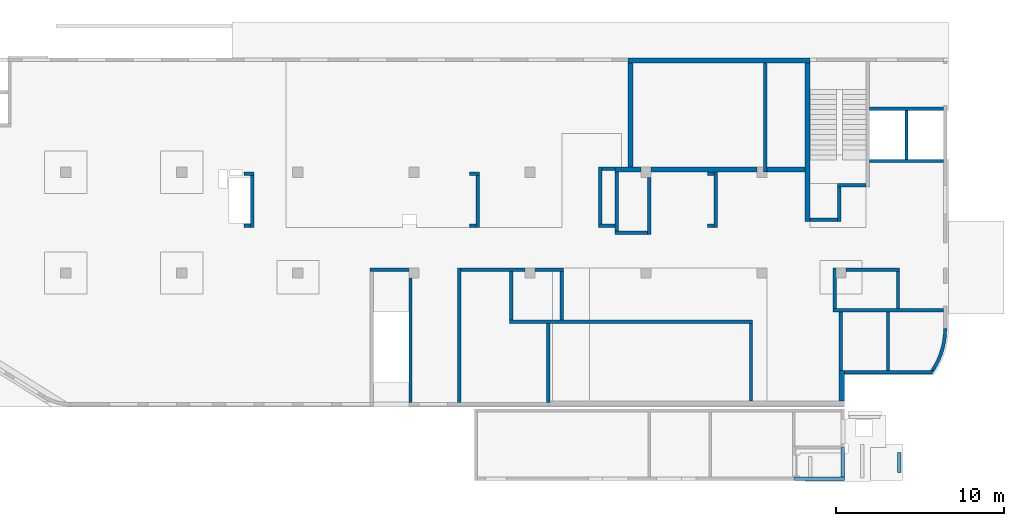
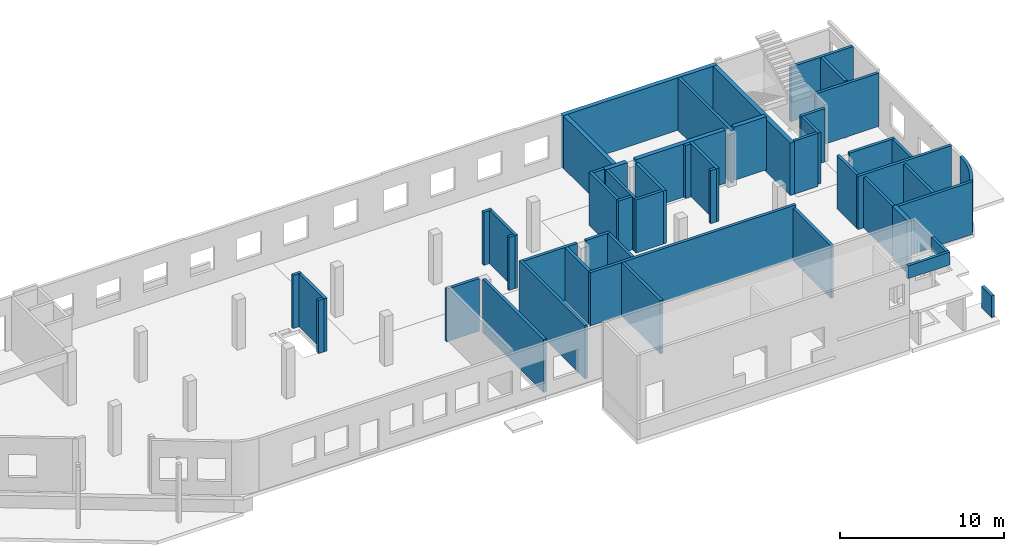
# One storey, part 3 of 8: 50 walls.
"""IFC4 building model written with IfcOpenShell, lengths in millimetres."""

import ifcopenshell
import ifcopenshell.guid

model = None  # the IFC model being written
_history = None  # IfcOwnerHistory: only IFC2X3 demands one
_inside = {}  # id of a spatial element -> (the spatial element, [elements in it])
_under = {}  # id of a project, library or spatial element -> (it, [spatial elements below it])
_declared = {}  # id of a project -> (the project, [libraries it declares])
_typed = {}  # id of a type object -> (the type object, [elements of that type])
_made_of = {}  # id of a material, layer set ... -> (it, [elements and type objects made of it])


def new_model(schema):
    """Start an empty IFC model of exactly this schema.

    Asked for "IFC4X3", IfcOpenShell would pick the latest addendum, in which some entities
    have other attributes; the version numbers below select the first issue.
    IFC2X3 requires an IfcOwnerHistory on every rooted entity: one is made here for all.
    """
    global model, _history
    if schema == "IFC4X3":
        model = ifcopenshell.file(schema_version=(4, 3, 0, 0))
    else:
        model = ifcopenshell.file(schema=schema)
    _inside.clear()
    _under.clear()
    _declared.clear()
    _typed.clear()
    _made_of.clear()
    _history = None
    if model.schema == "IFC2X3":
        org = make("IfcOrganization", Name="unknown")
        user = make(
            "IfcPersonAndOrganization",
            ThePerson=make("IfcPerson", FamilyName="unknown"),
            TheOrganization=org,
        )
        app = make(
            "IfcApplication",
            ApplicationDeveloper=org,
            Version="unknown",
            ApplicationFullName="unknown",
            ApplicationIdentifier="unknown",
        )
        _history = make(
            "IfcOwnerHistory",
            OwningUser=user,
            OwningApplication=app,
            ChangeAction="ADDED",
            CreationDate=0,
        )
    return model


def make(cls, **values):
    """One entity of the class cls with the attributes given. An attribute that is None is left unset."""
    return model.create_entity(
        cls, **{name: value for name, value in values.items() if value is not None}
    )


def entity(cls, *values):
    """Any entity or typed value of the class cls, its attributes in the order of the schema. None: left unset."""
    e = model.create_entity(cls)
    for i, value in enumerate(values):
        if value is not None:
            e[i] = value
    return e


def rooted(cls, **values):
    """An entity with a GlobalId (a new one), such as an element, a storey or a relation."""
    return make(cls, GlobalId=ifcopenshell.guid.new(), OwnerHistory=_history, **values)


def si_unit(unit_type, name, prefix=None):
    """IfcSIUnit, for example si_unit("LENGTHUNIT", "METRE", prefix="MILLI")."""
    return make("IfcSIUnit", UnitType=unit_type, Prefix=prefix, Name=name)


def converted_unit(unit_type, name, factor, base, dimensions=None, offset=None):
    """IfcConversionBasedUnit, such as the inch: factor (a typed value) times the base unit."""
    return make(
        "IfcConversionBasedUnit"
        if offset is None
        else "IfcConversionBasedUnitWithOffset",
        ConversionOffset=offset,
        Dimensions=None
        if dimensions is None
        else entity("IfcDimensionalExponents", *dimensions),
        UnitType=unit_type,
        Name=name,
        ConversionFactor=make(
            "IfcMeasureWithUnit", ValueComponent=factor, UnitComponent=base
        ),
    )


def derived_unit(unit_type, elements):
    """IfcDerivedUnit: a product of units, each with its exponent."""
    return make(
        "IfcDerivedUnit",
        Elements=[
            make("IfcDerivedUnitElement", Unit=unit, Exponent=power)
            for unit, power in elements
        ],
        UnitType=unit_type,
    )


def assignment(units):
    """IfcUnitAssignment: the units of a project."""
    return None if units is None else make("IfcUnitAssignment", Units=units)


def point(xyz):
    """IfcCartesianPoint."""
    return None if xyz is None else make("IfcCartesianPoint", Coordinates=xyz)


def direction(xyz):
    """IfcDirection."""
    return None if xyz is None else make("IfcDirection", DirectionRatios=xyz)


def frame(location, z_axis=None, x_axis=None):
    """IfcAxis2Placement3D, a coordinate frame: its origin and axes. An axis left out is left unset."""
    return make(
        "IfcAxis2Placement3D",
        Location=point(location),
        Axis=direction(z_axis),
        RefDirection=direction(x_axis),
    )


def origin():
    """The frame at (0, 0, 0) with its axes left unset."""
    return frame((0.0, 0.0, 0.0))


def place(relative_to, where):
    """IfcLocalPlacement: puts the frame where relative to a parent placement (None: the world)."""
    return make(
        "IfcLocalPlacement", PlacementRelTo=relative_to, RelativePlacement=where
    )


def context(
    kind, dimensions, precision=None, world=None, true_north=None, identifier=None
):
    """IfcGeometricRepresentationContext, for example the 3D "Model" context."""
    return make(
        "IfcGeometricRepresentationContext",
        ContextIdentifier=identifier,
        ContextType=kind,
        CoordinateSpaceDimension=dimensions,
        Precision=precision,
        WorldCoordinateSystem=world,
        TrueNorth=true_north,
    )


def subcontext(parent, identifier, kind, view, scale=None):
    """IfcGeometricRepresentationSubContext, for example "Body" below "Model"."""
    return make(
        "IfcGeometricRepresentationSubContext",
        ContextIdentifier=identifier,
        ContextType=kind,
        ParentContext=parent,
        TargetScale=scale,
        TargetView=view,
    )


def project(units=None, contexts=None):
    """IfcProject with its units and contexts."""
    return rooted(
        "IfcProject",
        Name="project",
        RepresentationContexts=contexts,
        UnitsInContext=assignment(units),
    )


def spatial(cls, under=None, at=None, **own):
    """A site, building, storey or space (cls), placed at a placement, below another one or the project."""
    s = rooted(cls, ObjectPlacement=at, **own)
    if under is not None:
        _under.setdefault(under.id(), (under, []))[1].append(s)
    return s


def point_list(points):
    """IfcCartesianPointList2D or 3D."""
    cls = (
        "IfcCartesianPointList2D" if len(points[0]) == 2 else "IfcCartesianPointList3D"
    )
    return make(cls, CoordList=points)


def indexed_curve(points, segments=None, self_intersect=None):
    """IfcIndexedPolyCurve: lines and arcs through numbered points (the first is 1)."""
    return make(
        "IfcIndexedPolyCurve",
        Points=point_list(points),
        Segments=segments,
        SelfIntersect=self_intersect,
    )


def outline(outer, holes=None, kind="AREA"):
    """IfcArbitraryClosedProfileDef: a profile drawn as a closed curve; with holes, ...WithVoids."""
    if holes is None:
        return make("IfcArbitraryClosedProfileDef", ProfileType=kind, OuterCurve=outer)
    return make(
        "IfcArbitraryProfileDefWithVoids",
        ProfileType=kind,
        OuterCurve=outer,
        InnerCurves=holes,
    )


def extrude(swept, where, along, depth):
    """IfcExtrudedAreaSolid: the profile swept, set in the frame where, extruded along a direction by depth."""
    return make(
        "IfcExtrudedAreaSolid",
        SweptArea=swept,
        Position=where,
        ExtrudedDirection=direction(along),
        Depth=depth,
    )


def shape(context_of_items, identifier, shape_type, items):
    """IfcShapeRepresentation: the items that make up one representation, for example the "Body"."""
    return make(
        "IfcShapeRepresentation",
        ContextOfItems=context_of_items,
        RepresentationIdentifier=identifier,
        RepresentationType=shape_type,
        Items=items,
    )


def material(Name=None, Category=None):
    """IfcMaterial."""
    return make("IfcMaterial", Name=Name, Category=Category)


def made_of(thing, what):
    """Note that an element or type object is made of a material, layer set ...; save() writes the relation."""
    if what is not None:
        _made_of.setdefault(what.id(), (what, []))[1].append(thing)
    return thing


def type_object(cls, material=None, **own):
    """A type object (cls), such as IfcWallType, which elements share."""
    return made_of(rooted(cls, **own), material)


def element(
    cls,
    number,
    at=None,
    inside=None,
    cuts=None,
    type_object=None,
    material=None,
    context=None,
    identifier="Body",
    shape_type=None,
    held_by="IfcProductDefinitionShape",
    body=None,
    shapes=None,
    **own,
):
    """One element of the class cls, such as IfcWall. Its Tag is "e" and its number.

    at: its placement. inside: the storey or other place that contains it. cuts: it is an
    opening in that element (IfcRelVoidsElement). A single representation is given by context,
    identifier, shape_type and body (its items); several are given by shapes. held_by: the class
    of the entity that holds the representations. save() writes the other relations.
    """
    e = rooted(cls, Tag="e%d" % number, ObjectPlacement=at, **own)
    if body is not None:
        shapes = [shape(context, identifier, shape_type, body)]
    if shapes is not None:
        e.Representation = make(held_by, Representations=shapes)
    if inside is not None:
        _inside.setdefault(inside.id(), (inside, []))[1].append(e)
    if cuts is not None:
        rooted(
            "IfcRelVoidsElement", RelatingBuildingElement=cuts, RelatedOpeningElement=e
        )
    if type_object is not None:
        _typed.setdefault(type_object.id(), (type_object, []))[1].append(e)
    return made_of(e, material)


def aggregate(whole, parts):
    """IfcRelAggregates: a whole, such as a stair, and the parts it consists of."""
    return rooted("IfcRelAggregates", RelatingObject=whole, RelatedObjects=parts)


def save(model, path):
    """Write the relations noted so far, then the file.

    IfcRelAggregates (storeys below a building ...), IfcRelContainedInSpatialStructure (elements
    in a storey), IfcRelDefinesByType, IfcRelAssociatesMaterial and IfcRelDeclares: one each for
    every whole, place, type object, material and project.
    """
    for whole, parts in _under.values():
        aggregate(whole, parts)
    for where, things in _inside.values():
        rooted(
            "IfcRelContainedInSpatialStructure",
            RelatedElements=things,
            RelatingStructure=where,
        )
    for kind, things in _typed.values():
        rooted("IfcRelDefinesByType", RelatedObjects=things, RelatingType=kind)
    for what, things in _made_of.values():
        rooted("IfcRelAssociatesMaterial", RelatedObjects=things, RelatingMaterial=what)
    for by, libraries in _declared.values():
        rooted("IfcRelDeclares", RelatingContext=by, RelatedDefinitions=libraries)
    model.write(path)


model = new_model("IFC4")

# Units and contexts
model_context = context("Model", 3, precision=0.01, world=origin(), true_north=direction((6.12303176911189e-17, 1.0)))
plan_context = context("Plan", 3, precision=0.01, world=origin(), true_north=direction((6.12303176911189e-17, 1.0)))
body_context = subcontext(model_context, "Body", "Model", "MODEL_VIEW")
ifc_project = project(units=[si_unit("LENGTHUNIT", "METRE", prefix="MILLI"), si_unit("AREAUNIT", "SQUARE_METRE"), si_unit("VOLUMEUNIT", "CUBIC_METRE"), converted_unit("PLANEANGLEUNIT", "DEGREE", entity("IfcRatioMeasure", 0.0174532925199433), si_unit("PLANEANGLEUNIT", "RADIAN"), dimensions=[0, 0, 0, 0, 0, 0, 0]), si_unit("MASSUNIT", "GRAM", prefix="KILO"), derived_unit("MASSDENSITYUNIT", [(si_unit("MASSUNIT", "GRAM", prefix="KILO"), 1), (si_unit("LENGTHUNIT", "METRE"), -3)]), derived_unit("MOMENTOFINERTIAUNIT", [(si_unit("LENGTHUNIT", "METRE"), 4)]), si_unit("TIMEUNIT", "SECOND"), si_unit("FREQUENCYUNIT", "HERTZ"), si_unit("THERMODYNAMICTEMPERATUREUNIT", "DEGREE_CELSIUS"), derived_unit("THERMALTRANSMITTANCEUNIT", [(si_unit("MASSUNIT", "GRAM", prefix="KILO"), 1), (si_unit("THERMODYNAMICTEMPERATUREUNIT", "KELVIN"), -1), (si_unit("TIMEUNIT", "SECOND"), -3)]), derived_unit("VOLUMETRICFLOWRATEUNIT", [(si_unit("LENGTHUNIT", "METRE"), 3), (si_unit("TIMEUNIT", "SECOND"), -1)]), derived_unit("MASSFLOWRATEUNIT", [(si_unit("MASSUNIT", "GRAM", prefix="KILO"), 1), (si_unit("TIMEUNIT", "SECOND"), -1)]), derived_unit("ROTATIONALFREQUENCYUNIT", [(si_unit("TIMEUNIT", "SECOND"), -1)]), si_unit("ELECTRICCURRENTUNIT", "AMPERE"), si_unit("ELECTRICVOLTAGEUNIT", "VOLT"), si_unit("POWERUNIT", "WATT"), si_unit("FORCEUNIT", "NEWTON", prefix="KILO"), si_unit("ILLUMINANCEUNIT", "LUX"), si_unit("LUMINOUSFLUXUNIT", "LUMEN"), si_unit("LUMINOUSINTENSITYUNIT", "CANDELA"), derived_unit("USERDEFINED", [(si_unit("MASSUNIT", "GRAM", prefix="KILO"), -1), (si_unit("LENGTHUNIT", "METRE"), -2), (si_unit("TIMEUNIT", "SECOND"), 3), (si_unit("LUMINOUSFLUXUNIT", "LUMEN"), 1)]), derived_unit("LINEARVELOCITYUNIT", [(si_unit("LENGTHUNIT", "METRE"), 1), (si_unit("TIMEUNIT", "SECOND"), -1)]), si_unit("PRESSUREUNIT", "PASCAL"), derived_unit("USERDEFINED", [(si_unit("LENGTHUNIT", "METRE"), -2), (si_unit("MASSUNIT", "GRAM", prefix="KILO"), 1), (si_unit("TIMEUNIT", "SECOND"), -2)]), derived_unit("LINEARFORCEUNIT", [(si_unit("MASSUNIT", "GRAM", prefix="KILO"), 1), (si_unit("LENGTHUNIT", "METRE"), 1), (si_unit("TIMEUNIT", "SECOND"), -2), (si_unit("LENGTHUNIT", "METRE"), -1)]), derived_unit("PLANARFORCEUNIT", [(si_unit("MASSUNIT", "GRAM", prefix="KILO"), 1), (si_unit("LENGTHUNIT", "METRE"), 1), (si_unit("TIMEUNIT", "SECOND"), -2), (si_unit("LENGTHUNIT", "METRE"), -2)])], contexts=[model_context, plan_context])

# Site, building, storey
site_placement = place(None, origin())
site = spatial("IfcSite", under=ifc_project, at=site_placement, CompositionType="ELEMENT")
building_placement = place(site_placement, origin())
building = spatial("IfcBuilding", under=site, at=building_placement, CompositionType="ELEMENT")
storey_placement = place(building_placement, origin())
storey = spatial("IfcBuildingStorey", under=building, at=storey_placement, CompositionType="ELEMENT", Elevation=0.0)

# Walls
ifc_material = material()
wall_type_1 = type_object("IfcWallType", PredefinedType="STANDARD")
wall_1_placement = place(storey_placement, frame((41670.0002685547, 7399.99922635609, 0.0), z_axis=(0.0, 0.0, 1.0), x_axis=(0.0, -1.0, 0.0)))
element("IfcWall", 1, at=wall_1_placement, inside=storey, type_object=wall_type_1, material=ifc_material, PredefinedType="NOTDEFINED", context=body_context, shape_type="SweptSolid", body=[
    extrude(outline(indexed_curve([(7399.9999999999, 100.000000000003), (-1.17863088903232e-13, 100.000000000003), (1.17863088903232e-13, -100.000000000003), (7399.9999999999, -100.000000000003), (7399.9999999999, 100.000000000003)], self_intersect=False)), origin(), (0.0, 0.0, 1.0), 3950.0),
])
wall_2_placement = place(storey_placement, frame((41570.0002685547, 7899.99922635609, -150.0), z_axis=(0.0, 0.0, 1.0), x_axis=(-1.0, 0.0, 0.0)))
element("IfcWall", 2, at=wall_2_placement, inside=storey, type_object=wall_type_1, material=ifc_material, PredefinedType="NOTDEFINED", context=body_context, shape_type="SweptSolid", body=[
    extrude(outline(indexed_curve([(2300.00000000001, 100.0), (-3.29568256742987e-13, 100.0), (3.29568256742987e-13, -100.0), (2300.00000000001, -100.0), (2300.00000000001, 100.0)], self_intersect=False)), origin(), (0.0, 0.0, 1.0), 3900.0),
])
wall_3_placement = place(storey_placement, frame((44570.0002685546, -0.000773643820389016, 0.0), z_axis=(0.0, 0.0, 1.0), x_axis=(0.0, 1.0, 0.0)))
element("IfcWall", 3, at=wall_3_placement, inside=storey, type_object=wall_type_1, material=ifc_material, PredefinedType="NOTDEFINED", context=body_context, shape_type="SweptSolid", body=[
    extrude(outline(indexed_curve([(7999.9999999999, 100.000000000007), (-3.96878629442861e-20, 100.000000000003), (3.96878629442861e-20, -100.000000000003), (7999.9999999999, -99.9999999999995), (7999.9999999999, 100.000000000007)], self_intersect=False)), origin(), (0.0, 0.0, 1.0), 3950.0),
])
wall_4_placement = place(storey_placement, frame((48470.0002685546, 7899.99922635607, 0.0), z_axis=(0.0, 0.0, 1.0), x_axis=(-1.0, 0.0, 0.0)))
element("IfcWall", 4, at=wall_4_placement, inside=storey, type_object=wall_type_1, material=ifc_material, PredefinedType="NOTDEFINED", context=body_context, shape_type="SweptSolid", body=[
    extrude(outline(indexed_curve([(3800.0, 100.0), (-3.42426881021964e-13, 100.0), (3.42426881021964e-13, -100.0), (3800.0, -100.0), (3800.0, 100.0)], self_intersect=False)), origin(), (0.0, 0.0, 1.0), 3950.0),
])
wall_5_placement = place(storey_placement, frame((49070.0002685546, 7899.99922635606, 0.0)))
element("IfcWall", 5, at=wall_5_placement, inside=storey, type_object=wall_type_1, material=ifc_material, PredefinedType="NOTDEFINED", context=body_context, shape_type="SweptSolid", body=[
    extrude(outline(indexed_curve([(1700.0, 100.0), (-3.18490332146586e-13, 100.0), (3.18490332146586e-13, -100.0), (1700.0, -100.0), (1700.0, 100.0)], self_intersect=False)), origin(), (0.0, 0.0, 1.0), 3950.0),
])
wall_6_placement = place(storey_placement, frame((50670.0002685546, 7799.99922635606, 0.0), z_axis=(0.0, 0.0, 1.0), x_axis=(0.0, -1.0, 0.0)))
element("IfcWall", 6, at=wall_6_placement, inside=storey, type_object=wall_type_1, material=ifc_material, PredefinedType="NOTDEFINED", context=body_context, shape_type="SweptSolid", body=[
    extrude(outline(indexed_curve([(2899.99999999996, 100.000000000003), (0.0, 100.000000000003), (0.0, -100.000000000003), (2899.99999999996, -100.000000000003), (2899.99999999996, 100.000000000003)], self_intersect=False)), origin(), (0.0, 0.0, 1.0), 3950.0),
])
wall_7_placement = place(storey_placement, frame((62020.0002685547, 4799.99922635607, 0.0), z_axis=(0.0, 0.0, 1.0), x_axis=(-1.0, 0.0, 0.0)))
element("IfcWall", 7, at=wall_7_placement, inside=storey, type_object=wall_type_1, material=ifc_material, PredefinedType="NOTDEFINED", context=body_context, shape_type="SweptSolid", body=[
    extrude(outline(indexed_curve([(14450.0, 99.9999999999999), (-3.06338005499363e-13, 100.0), (3.06338005499363e-13, -100.0), (14450.0, -100.0), (14450.0, 99.9999999999999)], self_intersect=False)), origin(), (0.0, 0.0, 1.0), 3950.0),
])
wall_8_placement = place(storey_placement, frame((47670.0002685546, 7799.99922635607, 0.0), z_axis=(0.0, 0.0, 1.0), x_axis=(0.0, -1.0, 0.0)))
element("IfcWall", 8, at=wall_8_placement, inside=storey, type_object=wall_type_1, material=ifc_material, PredefinedType="NOTDEFINED", context=body_context, shape_type="SweptSolid", body=[
    extrude(outline(indexed_curve([(2899.99999999996, 100.000000000003), (0.0, 100.000000000003), (0.0, -100.000000000003), (2899.99999999996, -100.000000000003), (2899.99999999996, 100.000000000003)], self_intersect=False)), origin(), (0.0, 0.0, 1.0), 3950.0),
])
wall_9_placement = place(storey_placement, frame((49870.0002685546, -0.000773643837420837, 0.0), z_axis=(0.0, 0.0, 1.0), x_axis=(0.0, 1.0, 0.0)))
element("IfcWall", 9, at=wall_9_placement, inside=storey, type_object=wall_type_1, material=ifc_material, PredefinedType="NOTDEFINED", context=body_context, shape_type="SweptSolid", body=[
    extrude(outline(indexed_curve([(4699.99999999994, 99.9999999999998), (3.10976382565532e-20, 100.000000000003), (-3.10976382565532e-20, -100.000000000003), (4699.99999999994, -100.000000000007), (4699.99999999994, 99.9999999999998)], self_intersect=False)), origin(), (0.0, 0.0, 1.0), 3950.0),
])
wall_10_placement = place(storey_placement, frame((61920.0002685546, 4699.99922635607, -150.0), z_axis=(0.0, 0.0, 1.0), x_axis=(0.0, -1.0, 0.0)))
element("IfcWall", 10, at=wall_10_placement, inside=storey, type_object=wall_type_1, material=ifc_material, PredefinedType="NOTDEFINED", context=body_context, shape_type="SweptSolid", body=[
    extrude(outline(indexed_curve([(4599.99999999994, 100.000000000006), (-2.40637139844096e-13, 100.000000000003), (2.40637139844096e-13, -100.000000000003), (4599.99999999994, -100.000000000001), (4599.99999999994, 100.000000000006)], self_intersect=False)), origin(), (0.0, 0.0, 1.0), 3900.0),
])
wall_11_placement = place(storey_placement, frame((67270.0002685546, 1794.99922635611, 0.0), z_axis=(0.0, 0.0, 1.0), x_axis=(0.0, 1.0, 0.0)))
element("IfcWall", 11, at=wall_11_placement, inside=storey, type_object=wall_type_1, material=ifc_material, PredefinedType="NOTDEFINED", context=body_context, shape_type="SweptSolid", body=[
    extrude(outline(indexed_curve([(3604.99999999987, 100.000000000006), (-4.66276854653109e-14, 100.000000000003), (4.66276854653109e-14, -100.000000000003), (3604.99999999987, -100.0), (3604.99999999987, 100.000000000006)], self_intersect=False)), origin(), (0.0, 0.0, 1.0), 3750.0),
])
wall_12_placement = place(storey_placement, frame((67370.0002685546, 1794.99922635611, -150.0)))
element("IfcWall", 12, at=wall_12_placement, inside=storey, type_object=wall_type_1, material=ifc_material, PredefinedType="NOTDEFINED", context=body_context, shape_type="SweptSolid", body=[
    extrude(outline(indexed_curve([(5320.61392813742, -100.000000000023), (5334.83556171488, -80.3298207855378), (5348.9532041316, -60.584872456016), (5362.96646230287, -40.7657047800855), (5376.87494605046, -20.8728695928891), (5390.67826811337, -0.906920780744112), (5404.3760441587, 19.1315857343014), (5417.96789279233, 39.2420920099402), (5431.45343556949, 59.4240380991268), (5444.83229700539, 79.6768620656952), (5458.10410458558, 99.999999999978), (5217.31502339911, 100.0), (99.9999999999943, 100.0), (99.9999999999949, -100.0), (5320.61392813742, -100.000000000023)], self_intersect=False)), origin(), (0.0, 0.0, 1.0), 3900.0),
])
wall_13_placement = place(storey_placement, frame((66795.0, 5499.99922635598, 0.0)))
element("IfcWall", 13, at=wall_13_placement, inside=storey, type_object=wall_type_1, material=ifc_material, PredefinedType="NOTDEFINED", context=body_context, shape_type="SweptSolid", body=[
    extrude(outline(indexed_curve([(6575.0002685548, 100.000000000001), (-3.21116670446023e-13, 100.0), (3.21116670446023e-13, -100.0), (6575.0002685548, -99.9999999999995), (6575.0002685548, 100.000000000001)], self_intersect=False)), origin(), (0.0, 0.0, 1.0), 3950.0),
])
wall_14_placement = place(storey_placement, frame((73470.0002685546, 4399.99913385884, -150.0)))
element("IfcWall", 14, at=wall_14_placement, inside=storey, type_object=wall_type_1, material=ifc_material, PredefinedType="NOTDEFINED", context=body_context, shape_type="SweptSolid", body=[
    extrude(outline(indexed_curve([(-641.895895414368, -2504.99990750277), (-504.115533634932, -2278.7932507463), (-379.582920453029, -2045.03160310687), (-268.710923968226, -1804.489964199), (-171.867122675117, -1557.96581162138), (-89.3725868152551, -1306.27645704658), (-21.500813919721, -1050.25633655401), (31.5231779285028, -790.754244189626), (69.5235961062065, -528.630517924081), (92.3744562625127, -264.754187338847), (99.9999999999513, -9.2496628161598e-05), (-99.9999999999599, 9.24965686039059e-05), (-108.068327086898, -266.334566127823), (-132.243226652315, -531.692480118633), (-172.436042031252, -795.100501785527), (-228.499374019115, -1055.59263428279), (-300.227621429127, -1312.21357421178), (-387.357735094033, -1564.02221500731), (-489.570182546934, -1810.0950982599), (-606.490119843403, -2049.52980031693), (-737.688766227591, -2281.44824174303), (-882.684976600846, -2504.99990750275), (-641.895895414368, -2504.99990750277)], self_intersect=False)), origin(), (0.0, 0.0, 1.0), 3900.0),
])
wall_15_placement = place(storey_placement, frame((66895.0, 7999.99922635617, 0.0), z_axis=(0.0, 0.0, 1.0), x_axis=(0.0, -1.0, 0.0)))
element("IfcWall", 15, at=wall_15_placement, inside=storey, type_object=wall_type_1, material=ifc_material, PredefinedType="NOTDEFINED", context=body_context, shape_type="SweptSolid", body=[
    extrude(outline(indexed_curve([(2400.0000000002, 100.000000000003), (0.0, 100.000000000003), (0.0, -100.000000000003), (2400.0000000002, -100.000000000003), (2400.0000000002, 100.000000000003)], self_intersect=False)), origin(), (0.0, 0.0, 1.0), 3950.0),
])
wall_16_placement = place(storey_placement, frame((67570.0002685546, 7899.99922635617, 0.0)))
element("IfcWall", 16, at=wall_16_placement, inside=storey, type_object=wall_type_1, material=ifc_material, PredefinedType="NOTDEFINED", context=body_context, shape_type="SweptSolid", body=[
    extrude(outline(indexed_curve([(3200.0, 99.9999999999998), (-3.30452149995528e-13, 100.0), (3.30452149995528e-13, -100.0), (3200.0, -100.0), (3200.0, 99.9999999999998)], self_intersect=False)), origin(), (0.0, 0.0, 1.0), 3950.0),
])
wall_17_placement = place(storey_placement, frame((70670.0002685546, 7799.99922635617, 0.0), z_axis=(0.0, 0.0, 1.0), x_axis=(0.0, -1.0, 0.0)))
element("IfcWall", 17, at=wall_17_placement, inside=storey, type_object=wall_type_1, material=ifc_material, PredefinedType="NOTDEFINED", context=body_context, shape_type="SweptSolid", body=[
    extrude(outline(indexed_curve([(2200.0000000002, 100.000000000003), (0.0, 100.000000000003), (0.0, -100.000000000003), (2200.0000000002, -100.000000000003), (2200.0000000002, 100.000000000003)], self_intersect=False)), origin(), (0.0, 0.0, 1.0), 3950.0),
])
wall_18_placement = place(storey_placement, frame((71170.0002685547, 17369.9992263555, -250.0), z_axis=(0.0, 0.0, 1.0), x_axis=(0.0, -1.0, 0.0)))
element("IfcWall", 18, at=wall_18_placement, inside=storey, type_object=wall_type_1, material=ifc_material, PredefinedType="NOTDEFINED", context=body_context, shape_type="SweptSolid", body=[
    extrude(outline(indexed_curve([(2899.9999999995, 100.000000000003), (-2.98721966703065e-13, 100.000000000003), (2.98721966703065e-13, -100.000000000003), (2899.99999999951, -100.000000000003), (2899.9999999995, 100.000000000003)], self_intersect=False)), origin(), (0.0, 0.0, 1.0), 4300.0),
])
wall_19_placement = place(storey_placement, frame((73370.0002685547, 14369.9992263559, 0.0), z_axis=(0.0, 0.0, 1.0), x_axis=(-1.0, 0.0, 0.0)))
element("IfcWall", 19, at=wall_19_placement, inside=storey, type_object=wall_type_1, material=ifc_material, PredefinedType="NOTDEFINED", context=body_context, shape_type="SweptSolid", body=[
    extrude(outline(indexed_curve([(4400.00000000001, 99.9999999999983), (-3.30182467507706e-13, 99.9999999999989), (3.30182467507706e-13, -99.9999999999989), (4400.00000000001, -99.9999999999995), (4400.00000000001, 99.9999999999983)], self_intersect=False)), origin(), (0.0, 0.0, 1.0), 3950.0),
])
wall_20_placement = place(storey_placement, frame((73370.0002685547, 17469.9992263554, 0.0), z_axis=(0.0, 0.0, 1.0), x_axis=(-1.0, 0.0, 0.0)))
element("IfcWall", 20, at=wall_20_placement, inside=storey, type_object=wall_type_1, material=ifc_material, PredefinedType="NOTDEFINED", context=body_context, shape_type="SweptSolid", body=[
    extrude(outline(indexed_curve([(4400.00000000001, 99.9999999999983), (-3.29568256742984e-13, 99.9999999999989), (3.29568256742984e-13, -99.9999999999989), (4400.00000000001, -99.9999999999996), (4400.00000000001, 99.9999999999983)], self_intersect=False)), origin(), (0.0, 0.0, 1.0), 4050.0),
])
wall_21_placement = place(storey_placement, frame((68770.0002685547, 12929.999226356, -150.0), z_axis=(0.0, 0.0, 1.0), x_axis=(-1.0, 0.0, 0.0)))
element("IfcWall", 21, at=wall_21_placement, inside=storey, type_object=wall_type_1, material=ifc_material, PredefinedType="NOTDEFINED", context=body_context, shape_type="SweptSolid", body=[
    extrude(outline(indexed_curve([(1689.99999999999, 99.9999999999992), (-3.99213688220603e-13, 99.9999999999989), (3.99213688220603e-13, -99.9999999999989), (1689.99999999999, -99.9999999999987), (1689.99999999999, 99.9999999999992)], self_intersect=False)), origin(), (0.0, 0.0, 1.0), 3950.0),
])
wall_22_placement = place(storey_placement, frame((67180.0002685547, 10783.7778331856, 0.0), z_axis=(0.0, 0.0, 1.0), x_axis=(0.0, 1.0, 0.0)))
element("IfcWall", 22, at=wall_22_placement, inside=storey, type_object=wall_type_1, material=ifc_material, PredefinedType="NOTDEFINED", context=body_context, shape_type="SweptSolid", body=[
    extrude(outline(indexed_curve([(2046.22139317037, 100.000000000003), (0.0, 100.000000000003), (0.0, -100.000000000003), (2046.22139317037, -100.000000000003), (2046.22139317037, 100.000000000003)], self_intersect=False)), origin(), (0.0, 0.0, 1.0), 3800.0),
])
wall_23_placement = place(storey_placement, frame((67080.0002685547, 10883.7778331856, -150.0), z_axis=(0.0, 0.0, 1.0), x_axis=(-1.0, 0.0, 0.0)))
element("IfcWall", 23, at=wall_23_placement, inside=storey, type_object=wall_type_1, material=ifc_material, PredefinedType="NOTDEFINED", context=body_context, shape_type="SweptSolid", body=[
    extrude(outline(indexed_curve([(1650.0, 99.9999999999989), (-2.62513243466275e-13, 99.9999999999989), (2.62513243466275e-13, -99.9999999999989), (1650.0, -99.9999999999989), (1650.0, 99.9999999999989)], self_intersect=False)), origin(), (0.0, 0.0, 1.0), 3950.0),
])
wall_24_placement = place(storey_placement, frame((62770.0002685547, 13699.9992263562, -150.0), z_axis=(0.0, 0.0, 1.0), x_axis=(0.0, 1.0, 0.0)))
element("IfcWall", 24, at=wall_24_placement, inside=storey, type_object=wall_type_1, material=ifc_material, PredefinedType="NOTDEFINED", context=body_context, shape_type="SweptSolid", body=[
    extrude(outline(indexed_curve([(6499.99999999978, 100.000000000003), (0.0, 100.000000000003), (0.0, -100.000000000003), (6499.99999999978, -100.000000000003), (6499.99999999978, 100.000000000003)], self_intersect=False)), origin(), (0.0, 0.0, 1.0), 3900.0),
])
wall_25_placement = place(storey_placement, frame((55870.0002685547, 13399.9992263562, 0.0), z_axis=(0.0, 0.0, 1.0), x_axis=(0.0, -1.0, 0.0)))
element("IfcWall", 25, at=wall_25_placement, inside=storey, type_object=wall_type_1, material=ifc_material, PredefinedType="NOTDEFINED", context=body_context, shape_type="SweptSolid", body=[
    extrude(outline(indexed_curve([(3400.0, 100.000000000003), (-1.27396132858709e-13, 100.000000000003), (1.27396132858709e-13, -100.000000000003), (3400.0, -100.000000000003), (3400.0, 100.000000000003)], self_intersect=False)), origin(), (0.0, 0.0, 1.0), 3950.0),
])
wall_26_placement = place(storey_placement, frame((55770.0002685546, 10099.9992263562, 0.0), z_axis=(0.0, 0.0, 1.0), x_axis=(-1.0, 0.0, 0.0)))
element("IfcWall", 26, at=wall_26_placement, inside=storey, type_object=wall_type_1, material=ifc_material, PredefinedType="NOTDEFINED", context=body_context, shape_type="SweptSolid", body=[
    extrude(outline(indexed_curve([(1940.00000000001, 99.9999999999985), (-3.10870946210073e-13, 99.9999999999989), (3.10870946210073e-13, -99.9999999999989), (1940.00000000001, -99.9999999999994), (1940.00000000001, 99.9999999999985)], self_intersect=False)), origin(), (0.0, 0.0, 1.0), 3950.0),
])
wall_27_placement = place(storey_placement, frame((59830.0002685547, 13699.9992263562, 0.0), z_axis=(0.0, 0.0, 1.0), x_axis=(0.0, -1.0, 0.0)))
element("IfcWall", 27, at=wall_27_placement, inside=storey, type_object=wall_type_1, material=ifc_material, PredefinedType="NOTDEFINED", context=body_context, shape_type="SweptSolid", body=[
    extrude(outline(indexed_curve([(3275.00000000016, 100.000000000003), (-2.64517161355341e-13, 100.000000000003), (2.64517161355341e-13, -100.000000000003), (3275.00000000016, -100.000000000003), (3275.00000000016, 100.000000000003)], self_intersect=False)), origin(), (0.0, 0.0, 1.0), 3950.0),
])
wall_28_placement = place(storey_placement, frame((59730.0002685547, 10524.999226356, 0.0), z_axis=(0.0, 0.0, 1.0), x_axis=(-1.0, 0.0, 0.0)))
element("IfcWall", 28, at=wall_28_placement, inside=storey, type_object=wall_type_1, material=ifc_material, PredefinedType="NOTDEFINED", context=body_context, shape_type="SweptSolid", body=[
    extrude(outline(indexed_curve([(400.000000000013, 99.9999999999982), (-3.6095570976612e-13, 99.9999999999989), (3.6095570976612e-13, -99.9999999999989), (400.000000000013, -99.9999999999996), (400.000000000013, 99.9999999999982)], self_intersect=False)), origin(), (0.0, 0.0, 1.0), 3950.0),
])
wall_29_placement = place(storey_placement, frame((59330.0002685547, 13599.999226356, 0.0)))
element("IfcWall", 29, at=wall_29_placement, inside=storey, type_object=wall_type_1, material=ifc_material, PredefinedType="NOTDEFINED", context=body_context, shape_type="SweptSolid", body=[
    extrude(outline(indexed_curve([(400.000000000003, 99.9999999999989), (-1.08286712929837e-12, 99.9999999999989), (1.08286712929837e-12, -99.9999999999989), (400.000000000005, -99.9999999999989), (400.000000000003, 99.9999999999989)], self_intersect=False)), origin(), (0.0, 0.0, 1.0), 3950.0),
])
wall_30_placement = place(storey_placement, frame((53930.0002685546, 10199.9992263562, 0.0), z_axis=(0.0, 0.0, 1.0), x_axis=(0.0, 1.0, 0.0)))
element("IfcWall", 30, at=wall_30_placement, inside=storey, type_object=wall_type_1, material=ifc_material, PredefinedType="NOTDEFINED", context=body_context, shape_type="SweptSolid", body=[
    extrude(outline(indexed_curve([(3500.0, 100.000000000003), (0.0, 100.000000000003), (0.0, -100.000000000003), (3500.0, -100.000000000003), (3500.0, 100.000000000003)], self_intersect=False)), origin(), (0.0, 0.0, 1.0), 3950.0),
])
wall_31_placement = place(storey_placement, frame((53830.0002685546, 10524.9992263562, 0.0), z_axis=(0.0, 0.0, 1.0), x_axis=(-1.0, 0.0, 0.0)))
element("IfcWall", 31, at=wall_31_placement, inside=storey, type_object=wall_type_1, material=ifc_material, PredefinedType="NOTDEFINED", context=body_context, shape_type="SweptSolid", body=[
    extrude(outline(indexed_curve([(979.999999999994, 99.9999999999989), (0.0, 99.9999999999989), (0.0, -99.9999999999989), (979.999999999994, -99.9999999999989), (979.999999999994, 99.9999999999989)], self_intersect=False)), origin(), (0.0, 0.0, 1.0), 3950.0),
])
wall_32_placement = place(storey_placement, frame((52950.0002685546, 10624.9992263562, 0.0), z_axis=(0.0, 0.0, 1.0), x_axis=(0.0, 1.0, 0.0)))
element("IfcWall", 32, at=wall_32_placement, inside=storey, type_object=wall_type_1, material=ifc_material, PredefinedType="NOTDEFINED", context=body_context, shape_type="SweptSolid", body=[
    extrude(outline(indexed_curve([(3375.00000000001, 100.000000000003), (0.0, 100.000000000003), (0.0, -100.000000000003), (3375.00000000001, -100.000000000003), (3375.00000000001, 100.000000000003)], self_intersect=False)), origin(), (0.0, 0.0, 1.0), 3950.0),
])
wall_33_placement = place(storey_placement, frame((53830.0002685546, 13899.9992263562, 0.0), z_axis=(0.0, 0.0, 1.0), x_axis=(-1.0, 0.0, 0.0)))
element("IfcWall", 33, at=wall_33_placement, inside=storey, type_object=wall_type_1, material=ifc_material, PredefinedType="NOTDEFINED", context=body_context, shape_type="SweptSolid", body=[
    extrude(outline(indexed_curve([(779.999999999996, 99.9999999999991), (-2.96675925835205e-13, 99.9999999999989), (2.96675925835205e-13, -99.9999999999989), (779.999999999996, -99.9999999999988), (779.999999999996, 99.9999999999991)], self_intersect=False)), origin(), (0.0, 0.0, 1.0), 3950.0),
])
wall_34_placement = place(storey_placement, frame((45170.0002685547, 13599.9992263561, 0.0)))
element("IfcWall", 34, at=wall_34_placement, inside=storey, type_object=wall_type_1, material=ifc_material, PredefinedType="NOTDEFINED", context=body_context, shape_type="SweptSolid", body=[
    extrude(outline(indexed_curve([(600.000000000002, 99.9999999999989), (-3.60955709766126e-13, 99.9999999999989), (3.60955709766126e-13, -99.9999999999989), (600.000000000003, -99.9999999999989), (600.000000000002, 99.9999999999989)], self_intersect=False)), origin(), (0.0, 0.0, 1.0), 3950.0),
])
wall_35_placement = place(storey_placement, frame((45670.0002685547, 13499.9992263561, 0.0), z_axis=(0.0, 0.0, 1.0), x_axis=(0.0, -1.0, 0.0)))
element("IfcWall", 35, at=wall_35_placement, inside=storey, type_object=wall_type_1, material=ifc_material, PredefinedType="NOTDEFINED", context=body_context, shape_type="SweptSolid", body=[
    extrude(outline(indexed_curve([(3075.0, 100.000000000003), (-2.81721529573577e-13, 100.000000000003), (2.81721529573577e-13, -100.000000000003), (3075.0, -100.000000000003), (3075.0, 100.000000000003)], self_intersect=False)), origin(), (0.0, 0.0, 1.0), 3950.0),
])
wall_36_placement = place(storey_placement, frame((45570.0002685547, 10524.9992263561, 0.0), z_axis=(0.0, 0.0, 1.0), x_axis=(-1.0, 0.0, 0.0)))
element("IfcWall", 36, at=wall_36_placement, inside=storey, type_object=wall_type_1, material=ifc_material, PredefinedType="NOTDEFINED", context=body_context, shape_type="SweptSolid", body=[
    extrude(outline(indexed_curve([(399.999999999995, 100.0), (-3.60955709766139e-13, 100.000000000001), (3.60955709766139e-13, -100.000000000001), (399.999999999996, -100.000000000002), (399.999999999995, 100.0)], self_intersect=False)), origin(), (0.0, 0.0, 1.0), 3950.0),
])
wall_37_placement = place(storey_placement, frame((31770.0002685547, 13599.9992263562, 0.0)))
element("IfcWall", 37, at=wall_37_placement, inside=storey, type_object=wall_type_1, material=ifc_material, PredefinedType="NOTDEFINED", context=body_context, shape_type="SweptSolid", body=[
    extrude(outline(indexed_curve([(599.999999999993, 99.9999999999989), (-3.60955709766126e-13, 99.9999999999989), (3.60955709766126e-13, -99.9999999999989), (599.999999999994, -99.9999999999989), (599.999999999993, 99.9999999999989)], self_intersect=False)), origin(), (0.0, 0.0, 1.0), 3950.0),
])
wall_38_placement = place(storey_placement, frame((32270.0002685547, 13499.9992263562, 0.0), z_axis=(0.0, 0.0, 1.0), x_axis=(0.0, -1.0, 0.0)))
element("IfcWall", 38, at=wall_38_placement, inside=storey, type_object=wall_type_1, material=ifc_material, PredefinedType="NOTDEFINED", context=body_context, shape_type="SweptSolid", body=[
    extrude(outline(indexed_curve([(3075.0, 99.9999999999989), (-2.81721529573565e-13, 99.9999999999989), (2.81721529573565e-13, -99.9999999999989), (3075.0, -99.9999999999989), (3075.0, 99.9999999999989)], self_intersect=False)), origin(), (0.0, 0.0, 1.0), 3950.0),
])
wall_39_placement = place(storey_placement, frame((32170.0002685546, 10524.9992263562, 0.0), z_axis=(0.0, 0.0, 1.0), x_axis=(-1.0, 0.0, 0.0)))
element("IfcWall", 39, at=wall_39_placement, inside=storey, type_object=wall_type_1, material=ifc_material, PredefinedType="NOTDEFINED", context=body_context, shape_type="SweptSolid", body=[
    extrude(outline(indexed_curve([(399.999999999987, 100.0), (-3.60955709766139e-13, 100.000000000001), (3.60955709766139e-13, -100.000000000001), (399.999999999987, -100.000000000002), (399.999999999987, 100.0)], self_intersect=False)), origin(), (0.0, 0.0, 1.0), 3950.0),
])
wall_40_placement = place(storey_placement, frame((70070.0, 1894.9992263561, 0.0), z_axis=(0.0, 0.0, 1.0), x_axis=(0.0, 1.0, 0.0)))
element("IfcWall", 40, at=wall_40_placement, inside=storey, type_object=wall_type_1, material=ifc_material, PredefinedType="NOTDEFINED", context=body_context, shape_type="SweptSolid", body=[
    extrude(outline(indexed_curve([(3504.99999999987, 100.000000000006), (-4.66276854653109e-14, 100.000000000003), (4.66276854653109e-14, -100.000000000003), (3504.99999999987, -100.000000000001), (3504.99999999987, 100.000000000006)], self_intersect=False)), origin(), (0.0, 0.0, 1.0), 3750.0),
])
wall_41_placement = place(storey_placement, frame((64500.003616884, -4520.00087534258, 3230.0)))
element("IfcWall", 41, at=wall_41_placement, inside=storey, type_object=wall_type_1, material=ifc_material, PredefinedType="NOTDEFINED", context=body_context, shape_type="SweptSolid", body=[
    extrude(outline(indexed_curve([(2969.99665167066, 100.0), (-3.32288148921946e-13, 100.0), (3.32288148921946e-13, -100.0), (2969.99665167066, -99.9999999999999), (2969.99665167066, 100.0)], self_intersect=False)), origin(), (0.0, 0.0, 1.0), 950.000000000001),
])
wall_42_placement = place(storey_placement, frame((67370.0002685546, -4420.00087534259, 3230.0), z_axis=(0.0, 0.0, 1.0), x_axis=(0.0, 1.0, 0.0)))
element("IfcWall", 42, at=wall_42_placement, inside=storey, type_object=wall_type_1, material=ifc_material, PredefinedType="NOTDEFINED", context=body_context, shape_type="SweptSolid", body=[
    extrude(outline(indexed_curve([(1750.00007018598, 100.000000000003), (0.0, 100.000000000003), (0.0, -100.000000000003), (1750.00007018598, -100.000000000003), (1750.00007018598, 100.000000000003)], self_intersect=False)), origin(), (0.0, 0.0, 1.0), 950.000000000001),
])
wall_43_placement = place(storey_placement, frame((70745.1283736532, -4154.59256989535, -2100.0), z_axis=(0.0, 0.0, 1.0), x_axis=(0.0, 1.0, 0.0)))
element("IfcWall", 43, at=wall_43_placement, inside=storey, type_object=wall_type_1, material=ifc_material, PredefinedType="NOTDEFINED", context=body_context, shape_type="SweptSolid", body=[
    extrude(outline(indexed_curve([(1200.0, 100.000000000003), (0.0, 100.000000000003), (0.0, -100.000000000003), (1200.0, -100.000000000003), (1200.0, 100.000000000003)], self_intersect=False)), origin(), (0.0, 0.0, 1.0), 1620.0),
])
wall_type_2 = type_object("IfcWallType", PredefinedType="STANDARD")
wall_44_placement = place(storey_placement, frame((67320.0002685546, 1894.99922635611, -150.0), z_axis=(0.0, 0.0, 1.0), x_axis=(0.0, -1.0, 0.0)))
element("IfcWall", 44, at=wall_44_placement, inside=storey, type_object=wall_type_2, material=ifc_material, PredefinedType="NOTDEFINED", context=body_context, shape_type="SweptSolid", body=[
    extrude(outline(indexed_curve([(1795.0, -150.000000000001), (1795.0, 150.000000000001), (250.000000000131, 150.000000000001), (200.000000000001, 150.000000000001), (1.08286712929839e-12, 150.000000000001), (0.0, -150.000000000001), (1795.0, -150.000000000001)], self_intersect=False)), origin(), (0.0, 0.0, 1.0), 3900.0),
])
wall_45_placement = place(storey_placement, frame((65280.0002685547, 10783.7778331856, -150.0), z_axis=(0.0, 0.0, 1.0), x_axis=(0.0, 1.0, 0.0)))
element("IfcWall", 45, at=wall_45_placement, inside=storey, type_object=wall_type_2, material=ifc_material, PredefinedType="NOTDEFINED", context=body_context, shape_type="SweptSolid", body=[
    extrude(outline(indexed_curve([(9416.22139317037, 150.000000000001), (0.0, 150.000000000001), (0.0, -150.000000000001), (9416.22139317037, -150.000000000001), (9416.22139317037, 150.000000000001)], self_intersect=False)), origin(), (0.0, 0.0, 1.0), 3900.0),
])
wall_46_placement = place(storey_placement, frame((65430.0002685547, 20349.999226356, -150.0), z_axis=(0.0, 0.0, 1.0), x_axis=(-1.0, 0.0, 0.0)))
element("IfcWall", 46, at=wall_46_placement, inside=storey, type_object=wall_type_2, material=ifc_material, PredefinedType="NOTDEFINED", context=body_context, shape_type="SweptSolid", body=[
    extrude(outline(indexed_curve([(10810.0, 150.000000000001), (-4.92247223397386e-13, 150.000000000001), (4.92247223397386e-13, -150.000000000001), (10810.0, -150.0), (10810.0, 150.000000000001)], self_intersect=False)), origin(), (0.0, 0.0, 1.0), 3900.0),
])
wall_47_placement = place(storey_placement, frame((54770.0002685547, 20199.999226356, -150.0), z_axis=(0.0, 0.0, 1.0), x_axis=(0.0, -1.0, 0.0)))
element("IfcWall", 47, at=wall_47_placement, inside=storey, type_object=wall_type_2, material=ifc_material, PredefinedType="NOTDEFINED", context=body_context, shape_type="SweptSolid", body=[
    extrude(outline(indexed_curve([(6199.99999999979, 150.000000000001), (0.0, 150.000000000001), (0.0, -150.000000000001), (6199.99999999979, -150.000000000001), (6199.99999999979, 150.000000000001)], self_intersect=False)), origin(), (0.0, 0.0, 1.0), 3900.0),
])
wall_48_placement = place(storey_placement, frame((55970.0002685547, 13849.9992263562, 0.0)))
element("IfcWall", 48, at=wall_48_placement, inside=storey, type_object=wall_type_2, material=ifc_material, PredefinedType="NOTDEFINED", context=body_context, shape_type="SweptSolid", body=[
    extrude(outline(indexed_curve([(6299.99999999999, 150.000000000001), (-4.64085912556457e-13, 150.000000000001), (4.64085912556457e-13, -150.000000000001), (6299.99999999999, -150.000000000001), (6299.99999999999, 150.000000000001)], self_intersect=False)), origin(), (0.0, 0.0, 1.0), 3950.0),
])
wall_49_placement = place(storey_placement, frame((62870.0002685546, 13849.9992263562, 0.0)))
element("IfcWall", 49, at=wall_49_placement, inside=storey, type_object=wall_type_2, material=ifc_material, PredefinedType="NOTDEFINED", context=body_context, shape_type="SweptSolid", body=[
    extrude(outline(indexed_curve([(2260.00000000001, 150.000000000001), (-4.31230272729446e-13, 150.000000000001), (4.31230272729446e-13, -150.000000000001), (2260.00000000002, -150.000000000001), (2260.00000000001, 150.000000000001)], self_intersect=False)), origin(), (0.0, 0.0, 1.0), 3950.0),
])
wall_50_placement = place(storey_placement, frame((55370.0002685547, 13849.9992263562, 0.0), z_axis=(0.0, 0.0, 1.0), x_axis=(-1.0, 0.0, 0.0)))
element("IfcWall", 50, at=wall_50_placement, inside=storey, type_object=wall_type_2, material=ifc_material, PredefinedType="NOTDEFINED", context=body_context, shape_type="SweptSolid", body=[
    extrude(outline(indexed_curve([(1540.00000000007, 150.0), (-4.06075173486894e-13, 150.000000000001), (4.06075173486894e-13, -150.000000000001), (1540.00000000008, -150.000000000001), (1540.00000000007, 150.0)], self_intersect=False)), origin(), (0.0, 0.0, 1.0), 3950.0),
])

save(model, "model.ifc")
